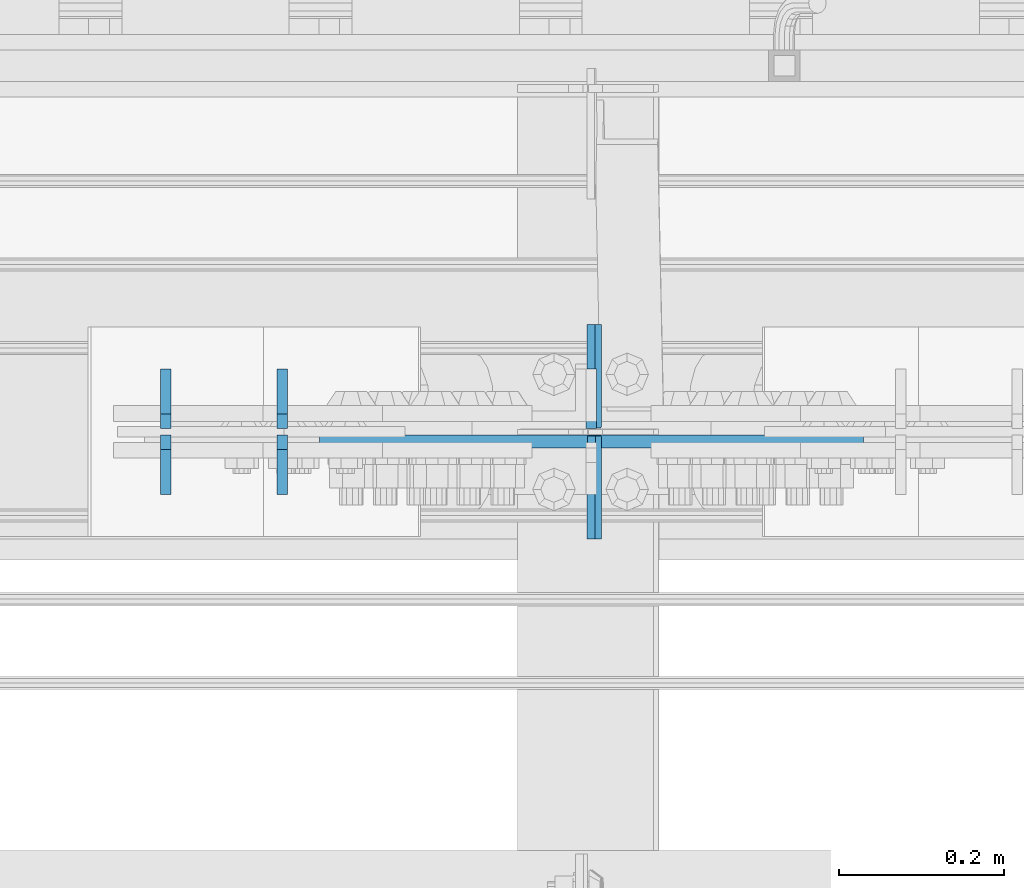
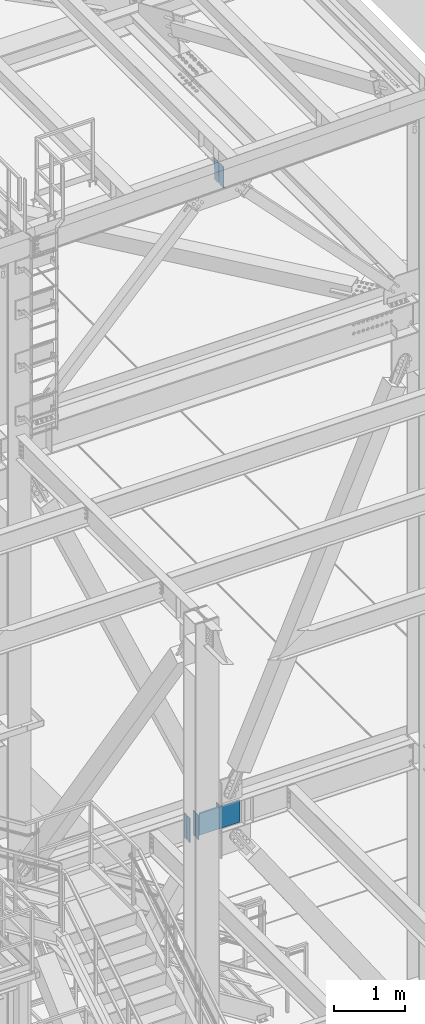
# One storey, part 3158 of 3843: 8 plates, 2 elements without a shape of their own.
"""IFC2X3 building model written with IfcOpenShell, lengths in millimetres."""

from ifc_helpers import new_model, si_unit, frame, origin_with_axes, place, context, subcontext, project, spatial, faceted_brep, material, type_object, element, aggregate, save


model = new_model("IFC2X3")

# Units and contexts
model_context = context("Model", 3, precision=1e-05, world=origin_with_axes())
body_context = subcontext(model_context, "Body", "Model", "MODEL_VIEW")
ifc_project = project(units=[si_unit("LENGTHUNIT", "METRE", prefix="MILLI"), si_unit("AREAUNIT", "SQUARE_METRE"), si_unit("VOLUMEUNIT", "CUBIC_METRE"), si_unit("MASSUNIT", "GRAM", prefix="KILO"), si_unit("TIMEUNIT", "SECOND"), si_unit("PLANEANGLEUNIT", "RADIAN"), si_unit("SOLIDANGLEUNIT", "STERADIAN"), si_unit("THERMODYNAMICTEMPERATUREUNIT", "DEGREE_CELSIUS"), si_unit("LUMINOUSINTENSITYUNIT", "LUMEN")], contexts=[model_context])

# Site, building, storey
site_placement = place(None, origin_with_axes())
site = spatial("IfcSite", under=ifc_project, at=site_placement, CompositionType="ELEMENT")
building_placement = place(site_placement, origin_with_axes())
building = spatial("IfcBuilding", under=site, at=building_placement, Name="Undefined", CompositionType="ELEMENT")
storey_placement = place(building_placement, origin_with_axes())
storey = spatial("IfcBuildingStorey", under=building, at=storey_placement, Name="Undefined", CompositionType="ELEMENT", Elevation=0.0)

# Assembly, plates
assembly_1_placement = place(storey_placement, origin_with_axes())
assembly_1 = element("IfcElementAssembly", 1, at=assembly_1_placement, inside=storey, Name="BEAM", AssemblyPlace="NOTDEFINED", PredefinedType="RIGID_FRAME")
ifc_material = material(Name="STEEL/A572-50")
plate_type_1 = type_object("IfcPlateType", PredefinedType="NOTDEFINED")
plate_1_placement = place(assembly_1_placement, frame((59291.9947383959, 25485.725, 45502.0096673006), z_axis=(-0.0211520980073474, 0.0, 0.999776269347241), x_axis=(0.0, 1.0, 0.0)))
plate_1 = element("IfcPlate", 2, at=plate_1_placement, type_object=plate_type_1, material=ifc_material, Name="STIFFENER", context=body_context, shape_type="Brep", body=[
    faceted_brep([(0.0, -4.76249999999709, 0.0), (0.0, -4.76249999999709, 377.824999997538), (0.0, 4.76249999999709, 377.824999997538), (0.0, 4.76249999999709, 0.0), (103.187499618536, -4.76249999999709, 377.824999997538), (103.187499618536, 4.76249999999709, 377.824999997538), (125.412500000006, -4.76249999999709, 355.599999616068), (125.412500000006, 4.76249999999709, 355.599999616068), (125.412500000006, -4.76249999999709, 22.2250003814697), (125.412500000006, 4.76249999999709, 22.2250003814697), (103.187499618536, -4.76249999999709, 0.0), (103.187499618536, 4.76249999999709, 0.0)], [[[0, 1, 2, 3]], [[1, 4, 5, 2]], [[4, 6, 7, 5]], [[6, 8, 9, 7]], [[8, 10, 11, 9]], [[10, 0, 3, 11]], [[5, 7, 9, 11, 3, 2]], [[10, 8, 6, 4, 1, 0]]]),
])
plate_2_placement = place(assembly_1_placement, frame((59291.9947383959, 25620.6625, 45502.0096673006), z_axis=(-0.0211520980073474, 0.0, 0.999776269347241), x_axis=(0.0, 1.0, 0.0)))
plate_2 = element("IfcPlate", 3, at=plate_2_placement, type_object=plate_type_1, material=ifc_material, Name="STIFFENER", context=body_context, shape_type="Brep", body=[
    faceted_brep([(0.0, -4.76249999999709, 22.2250003814697), (0.0, -4.76249999999709, 355.599999616068), (0.0, 4.76249999999709, 355.599999616068), (0.0, 4.76249999999709, 22.2250003814697), (22.2250003814697, -4.76249999999709, 377.824999997538), (22.2250003814697, 4.76249999999709, 377.824999997538), (125.412500000006, -4.76249999999709, 377.824999997538), (125.412500000006, 4.76249999999709, 377.824999997538), (125.412500000006, -4.76249999999709, 0.0), (125.412500000006, 4.76249999999709, 0.0), (22.2250003814697, -4.76249999999709, 0.0), (22.2250003814697, 4.76249999999709, 0.0)], [[[0, 1, 2, 3]], [[1, 4, 5, 2]], [[4, 6, 7, 5]], [[6, 8, 9, 7]], [[8, 10, 11, 9]], [[10, 0, 3, 11]], [[5, 7, 9, 11, 3, 2]], [[10, 8, 6, 4, 1, 0]]]),
])
aggregate(assembly_1, [plate_1, plate_2])

assembly_2_placement = place(storey_placement, origin_with_axes())
assembly_2 = element("IfcElementAssembly", 4, at=assembly_2_placement, inside=storey, Name="BEAM", AssemblyPlace="NOTDEFINED", PredefinedType="RIGID_FRAME")
plate_type_2 = type_object("IfcPlateType", PredefinedType="NOTDEFINED")
plate_3_placement = place(assembly_2_placement, frame((58767.6624993042, 25619.86875, 34372.55), z_axis=(0.0, 1.0, 0.0), x_axis=(0.0, 0.0, 1.0)))
plate_3 = element("IfcPlate", 5, at=plate_3_placement, type_object=plate_type_2, material=ifc_material, Name="CB_BEAM", context=body_context, shape_type="Brep", body=[
    faceted_brep([(0.0, -6.34999999999854, 17.4624996185303), (0.0, -6.34999999999854, 72.2312500000007), (0.0, 6.34999999999854, 72.2312500000007), (0.0, 6.34999999999854, 17.4624996185303), (425.449999999997, -6.34999999999854, 72.2312500000007), (425.449999999997, 6.34999999999854, 72.2312500000007), (425.449999999997, -6.34999999999854, 17.4624996185303), (425.449999999997, 6.34999999999854, 17.4624996185303), (407.987500381467, -6.34999999999854, 0.0), (407.987500381467, 6.34999999999854, 0.0), (17.4624996185303, -6.34999999999854, 0.0), (17.4624996185303, 6.34999999999854, 0.0)], [[[0, 1, 2, 3]], [[1, 4, 5, 2]], [[4, 6, 7, 5]], [[6, 8, 9, 7]], [[8, 10, 11, 9]], [[10, 0, 3, 11]], [[5, 7, 9, 11, 3, 2]], [[10, 8, 6, 4, 1, 0]]]),
])
plate_4_placement = place(assembly_2_placement, frame((58767.6624993042, 25611.93125, 34372.55), z_axis=(0.0, -1.0, 0.0), x_axis=(0.0, 0.0, 1.0)))
plate_4 = element("IfcPlate", 6, at=plate_4_placement, type_object=plate_type_2, material=ifc_material, Name="CB_BEAM", context=body_context, shape_type="Brep", body=[
    faceted_brep([(0.0, -6.34999999999854, 17.4624996185303), (0.0, -6.34999999999854, 72.2312500000007), (0.0, 6.34999999999854, 72.2312500000007), (0.0, 6.34999999999854, 17.4624996185303), (425.449999999997, -6.34999999999854, 72.2312500000007), (425.449999999997, 6.34999999999854, 72.2312500000007), (425.449999999997, -6.34999999999854, 17.4624996185303), (425.449999999997, 6.34999999999854, 17.4624996185303), (407.987500381467, -6.34999999999854, 0.0), (407.987500381467, 6.34999999999854, 0.0), (17.4624996185303, -6.34999999999854, 0.0), (17.4624996185303, 6.34999999999854, 0.0)], [[[0, 1, 2, 3]], [[1, 4, 5, 2]], [[4, 6, 7, 5]], [[6, 8, 9, 7]], [[8, 10, 11, 9]], [[10, 0, 3, 11]], [[5, 7, 9, 11, 3, 2]], [[10, 8, 6, 4, 1, 0]]]),
])
plate_5_placement = place(assembly_2_placement, frame((58908.9499993042, 25619.86875, 34372.55), z_axis=(0.0, 1.0, 0.0), x_axis=(0.0, 0.0, 1.0)))
plate_5 = element("IfcPlate", 7, at=plate_5_placement, type_object=plate_type_2, material=ifc_material, Name="CB_BEAM", context=body_context, shape_type="Brep", body=[
    faceted_brep([(0.0, -6.34999999999854, 17.4624996185303), (0.0, -6.34999999999854, 72.2312500000007), (0.0, 6.34999999999854, 72.2312500000007), (0.0, 6.34999999999854, 17.4624996185303), (425.449999999997, -6.34999999999854, 72.2312500000007), (425.449999999997, 6.34999999999854, 72.2312500000007), (425.449999999997, -6.34999999999854, 17.4624996185303), (425.449999999997, 6.34999999999854, 17.4624996185303), (407.987500381467, -6.34999999999854, 0.0), (407.987500381467, 6.34999999999854, 0.0), (17.4624996185303, -6.34999999999854, 0.0), (17.4624996185303, 6.34999999999854, 0.0)], [[[0, 1, 2, 3]], [[1, 4, 5, 2]], [[4, 6, 7, 5]], [[6, 8, 9, 7]], [[8, 10, 11, 9]], [[10, 0, 3, 11]], [[5, 7, 9, 11, 3, 2]], [[10, 8, 6, 4, 1, 0]]]),
])
plate_6_placement = place(assembly_2_placement, frame((58908.9499993042, 25611.93125, 34372.55), z_axis=(0.0, -1.0, 0.0), x_axis=(0.0, 0.0, 1.0)))
plate_6 = element("IfcPlate", 8, at=plate_6_placement, type_object=plate_type_2, material=ifc_material, Name="CB_BEAM", context=body_context, shape_type="Brep", body=[
    faceted_brep([(0.0, -6.34999999999854, 17.4624996185303), (0.0, -6.34999999999854, 72.2312500000007), (0.0, 6.34999999999854, 72.2312500000007), (0.0, 6.34999999999854, 17.4624996185303), (425.449999999997, -6.34999999999854, 72.2312500000007), (425.449999999997, 6.34999999999854, 72.2312500000007), (425.449999999997, -6.34999999999854, 17.4624996185303), (425.449999999997, 6.34999999999854, 17.4624996185303), (407.987500381467, -6.34999999999854, 0.0), (407.987500381467, 6.34999999999854, 0.0), (17.4624996185303, -6.34999999999854, 0.0), (17.4624996185303, 6.34999999999854, 0.0)], [[[0, 1, 2, 3]], [[1, 4, 5, 2]], [[4, 6, 7, 5]], [[6, 8, 9, 7]], [[8, 10, 11, 9]], [[10, 0, 3, 11]], [[5, 7, 9, 11, 3, 2]], [[10, 8, 6, 4, 1, 0]]]),
])
plate_7_placement = place(assembly_2_placement, frame((59284.3937493042, 25619.86875, 34372.55), z_axis=(0.0, 1.0, 0.0), x_axis=(0.0, 0.0, 1.0)))
plate_7 = element("IfcPlate", 9, at=plate_7_placement, type_object=plate_type_2, material=ifc_material, Name="CB_BEAM", context=body_context, shape_type="Brep", body=[
    faceted_brep([(0.0, -6.34999999999854, 17.4624996185303), (0.0, -6.34999999999854, 72.2312500000007), (0.0, 6.34999999999854, 72.2312500000007), (0.0, 6.34999999999854, 17.4624996185303), (425.449999999997, -6.34999999999854, 72.2312500000007), (425.449999999997, 6.34999999999854, 72.2312500000007), (425.449999999997, -6.34999999999854, 17.4624996185303), (425.449999999997, 6.34999999999854, 17.4624996185303), (407.987500381467, -6.34999999999854, 0.0), (407.987500381467, 6.34999999999854, 0.0), (17.4624996185303, -6.34999999999854, 0.0), (17.4624996185303, 6.34999999999854, 0.0)], [[[0, 1, 2, 3]], [[1, 4, 5, 2]], [[4, 6, 7, 5]], [[6, 8, 9, 7]], [[8, 10, 11, 9]], [[10, 0, 3, 11]], [[5, 7, 9, 11, 3, 2]], [[10, 8, 6, 4, 1, 0]]]),
])
plate_type_3 = type_object("IfcPlateType", PredefinedType="NOTDEFINED")
plate_8_placement = place(assembly_2_placement, frame((58954.1937493042, 25603.99375, 34388.4249996185), z_axis=(0.0, 0.0, 1.0), x_axis=(1.0, 0.0, 0.0)))
plate_8 = element("IfcPlate", 10, at=plate_8_placement, type_object=plate_type_3, material=ifc_material, Name="PLATE", context=body_context, shape_type="Brep", body=[
    faceted_brep([(0.0, 7.9375, 0.0), (660.400000000009, 7.9375, 0.0), (660.400000000009, -7.9375, 9.16543546213506), (0.0, -7.9375, 9.16543575970718), (660.400000000001, 7.9375, 393.700000762932), (660.400000000001, -7.9375, 384.534565300848), (0.0, -7.9375, 384.534565300848), (0.0, 7.9375, 393.700000762939)], [[[0, 1, 2, 3]], [[2, 1, 4, 5]], [[3, 2, 5, 6]], [[0, 3, 6, 7]], [[1, 0, 7, 4]], [[6, 5, 4, 7]]]),
])
aggregate(assembly_2, [plate_3, plate_4, plate_5, plate_6, plate_8, plate_7])

save(model, "model.ifc")
